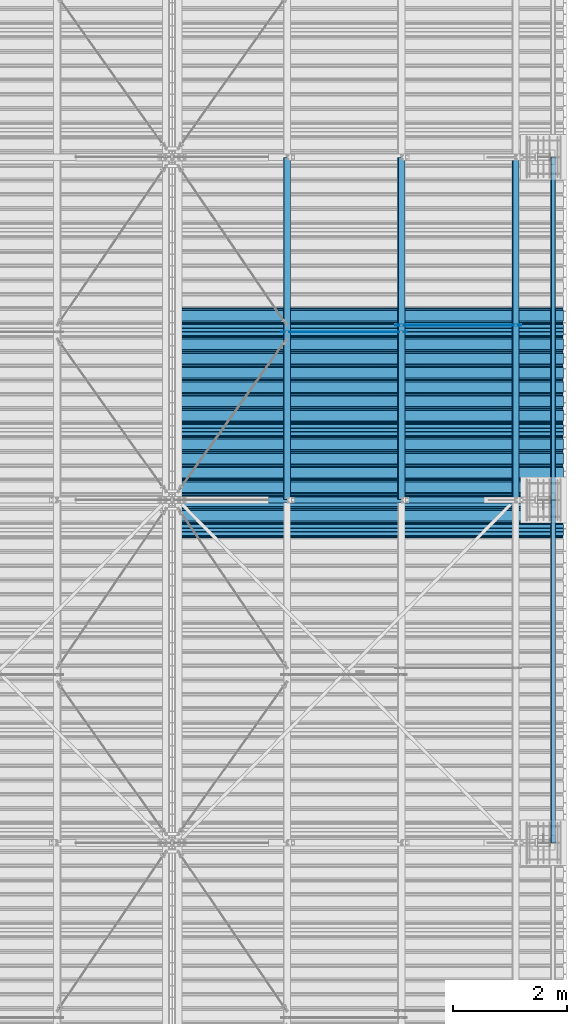
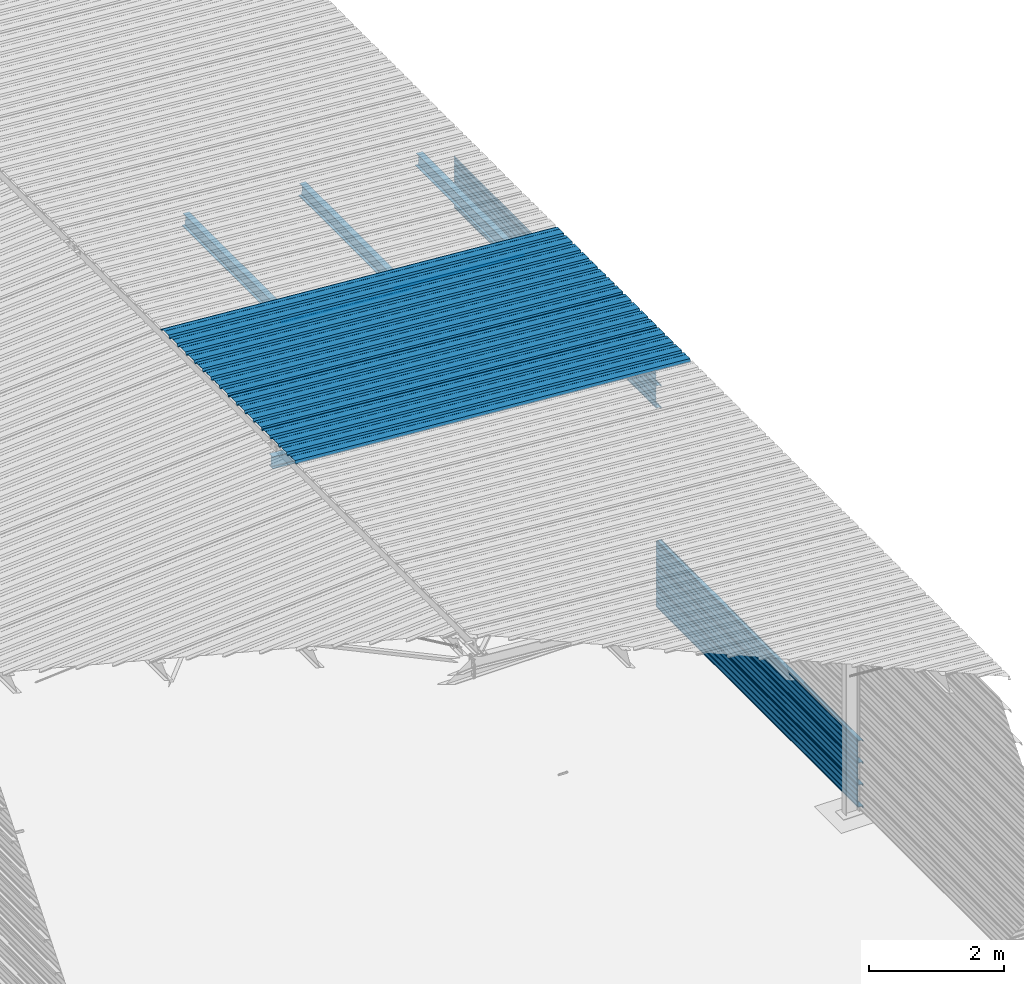
# One storey, part 14 of 70: 16 beams, 16 elements without a shape of their own.
"""IFC2X3 building model written with IfcOpenShell, lengths in millimetres."""

from ifc_helpers import new_model, si_unit, frame, origin_with_axes, origin_2d_with_axis, place, context, subcontext, project, spatial, polyline, circle, i_section, outline, extrude, clip, halfspace, material, type_object, element, aggregate, save


model = new_model("IFC2X3")

# Units and contexts
model_context = context("Model", 3, precision=1e-05, world=origin_with_axes())
body_context = subcontext(model_context, "Body", "Model", "MODEL_VIEW")
ifc_project = project(units=[si_unit("LENGTHUNIT", "METRE", prefix="MILLI"), si_unit("AREAUNIT", "SQUARE_METRE"), si_unit("VOLUMEUNIT", "CUBIC_METRE"), si_unit("MASSUNIT", "GRAM", prefix="KILO"), si_unit("TIMEUNIT", "SECOND"), si_unit("PLANEANGLEUNIT", "RADIAN"), si_unit("SOLIDANGLEUNIT", "STERADIAN"), si_unit("THERMODYNAMICTEMPERATUREUNIT", "DEGREE_CELSIUS"), si_unit("LUMINOUSINTENSITYUNIT", "LUMEN")], contexts=[model_context])

# Site, building, storey
site_placement = place(None, origin_with_axes())
site = spatial("IfcSite", under=ifc_project, at=site_placement, CompositionType="ELEMENT")
building_placement = place(site_placement, origin_with_axes())
building = spatial("IfcBuilding", under=site, at=building_placement, Name="Undefined", CompositionType="ELEMENT")
storey_placement = place(building_placement, origin_with_axes())
storey = spatial("IfcBuildingStorey", under=building, at=storey_placement, Name="Undefined", CompositionType="ELEMENT", Elevation=0.0)

# Assembly, beam
assembly_1_placement = place(storey_placement, origin_with_axes())
assembly_1 = element("IfcElementAssembly", 1, at=assembly_1_placement, inside=storey, Name="Steel Assembly", AssemblyPlace="NOTDEFINED", PredefinedType="RIGID_FRAME")
ifc_material = material(Name="STEEL/S235JR")
beam_type_1 = type_object("IfcBeamType", Name="4.40", PredefinedType="NOTDEFINED")
beam_1_placement = place(assembly_1_placement, frame((6563.60751131961, 11850.0000000002, 5336.31760454384), z_axis=(-0.0766964990376782, 0.0, -0.997054485489817), x_axis=(0.997054485489817, 0.0, -0.0766964990376783)))
beam_1 = element("IfcBeam", 2, at=beam_1_placement, type_object=beam_type_1, material=ifc_material, ObjectType="4.40", context=body_context, shape_type="SweptSolid", body=[
    extrude(outline(polyline([(509.415161132813, 19.5000000011705), (490.584838867188, 19.5000000011705), (468.084838867188, -20.4999999988113), (406.585784912109, -20.4999999988113), (404.585784912109, -18.4999999988122), (345.414215087891, -18.4999999988122), (343.414215087891, -20.4999999988113), (281.915161132813, -20.4999999988113), (259.415161132813, 19.5000000011705), (240.584854125977, 19.5000000011705), (218.084854125977, -20.4999999988113), (156.585784912109, -20.4999999988113), (154.585784912109, -18.4999999988122), (95.4142150878906, -18.4999999988122), (93.4142150878906, -20.4999999988113), (31.9151515960693, -20.4999999988113), (9.41515254974365, 19.5000000011705), (-9.41515254974365, 19.5000000011705), (-31.9151515960693, -20.4999999988113), (-93.4142150878906, -20.4999999988113), (-95.4142150878906, -18.4999999988122), (-154.585784912109, -18.4999999988122), (-156.585784912109, -20.4999999988113), (-218.084854125977, -20.4999999988113), (-240.584854125977, 19.5000000011705), (-259.415161132813, 19.5000000011705), (-281.915161132813, -20.4999999988113), (-343.414215087891, -20.4999999988113), (-345.414215087891, -18.4999999988122), (-404.585784912109, -18.4999999988122), (-406.585784912109, -20.4999999988113), (-468.084838867188, -20.4999999988113), (-490.584838867188, 19.5000000011705), (-509.415161132813, 19.5000000011705), (-516.482360839844, 6.9361057293263), (-517.353942871094, 7.42636680720625), (-510.0, 20.5000000011705), (-490.0, 20.5000000011705), (-467.5, -19.4999999988122), (-407.0, -19.4999999988122), (-405.0, -17.4999999988131), (-345.0, -17.4999999988131), (-343.0, -19.4999999988122), (-282.5, -19.4999999988122), (-260.0, 20.5000000011705), (-240.0, 20.5000000011705), (-217.5, -19.4999999988122), (-157.0, -19.4999999988122), (-155.0, -17.4999999988131), (-95.0, -17.4999999988131), (-93.0, -19.4999999988122), (-32.5, -19.4999999988122), (-10.0, 20.5000000011705), (10.0, 20.5000000011705), (32.5, -19.4999999988122), (93.0, -19.4999999988122), (95.0, -17.4999999988131), (155.0, -17.4999999988131), (157.0, -19.4999999988122), (217.5, -19.4999999988122), (240.0, 20.5000000011705), (260.0, 20.5000000011705), (282.5, -19.4999999988122), (343.0, -19.4999999988122), (345.0, -17.4999999988131), (405.0, -17.4999999988131), (407.0, -19.4999999988122), (467.5, -19.4999999988122), (490.0, 20.5000000011705), (510.0, 20.5000000011705), (517.353942871094, 7.42636680720625), (516.482360839844, 6.9361057293263), (509.415161132813, 19.5000000011705)])), frame((6799.99999999733, 2.8421709430404e-14, 0.0), z_axis=(-1.0, 0.0, 0.0), x_axis=(0.0, -1.0, 0.0)), (0.0, 0.0, 1.0), 6800.0),
])
aggregate(assembly_1, [beam_1])

assembly_2_placement = place(storey_placement, origin_with_axes())
assembly_2 = element("IfcElementAssembly", 3, at=assembly_2_placement, inside=storey, Name="Steel Assembly", AssemblyPlace="NOTDEFINED", PredefinedType="RIGID_FRAME")
beam_2_placement = place(assembly_2_placement, frame((6563.60751131961, 12850.0000000002, 5336.31760454387), z_axis=(-0.0766964990376782, 0.0, -0.997054485489817), x_axis=(0.997054485489817, 0.0, -0.0766964990376783)))
beam_2 = element("IfcBeam", 4, at=beam_2_placement, type_object=beam_type_1, material=ifc_material, ObjectType="4.40", context=body_context, shape_type="SweptSolid", body=[
    extrude(outline(polyline([(509.415161132813, 19.5000000011705), (490.584838867188, 19.5000000011705), (468.084838867188, -20.4999999988113), (406.585784912109, -20.4999999988113), (404.585784912109, -18.4999999988122), (345.414215087891, -18.4999999988122), (343.414215087891, -20.4999999988113), (281.915161132813, -20.4999999988113), (259.415161132813, 19.5000000011705), (240.584854125977, 19.5000000011705), (218.084854125977, -20.4999999988113), (156.585784912109, -20.4999999988113), (154.585784912109, -18.4999999988122), (95.4142150878906, -18.4999999988122), (93.4142150878906, -20.4999999988113), (31.9151515960693, -20.4999999988113), (9.41515254974365, 19.5000000011705), (-9.41515254974365, 19.5000000011705), (-31.9151515960693, -20.4999999988113), (-93.4142150878906, -20.4999999988113), (-95.4142150878906, -18.4999999988122), (-154.585784912109, -18.4999999988122), (-156.585784912109, -20.4999999988113), (-218.084854125977, -20.4999999988113), (-240.584854125977, 19.5000000011705), (-259.415161132813, 19.5000000011705), (-281.915161132813, -20.4999999988113), (-343.414215087891, -20.4999999988113), (-345.414215087891, -18.4999999988122), (-404.585784912109, -18.4999999988122), (-406.585784912109, -20.4999999988113), (-468.084838867188, -20.4999999988113), (-490.584838867188, 19.5000000011705), (-509.415161132813, 19.5000000011705), (-516.482360839844, 6.9361057293263), (-517.353942871094, 7.42636680720625), (-510.0, 20.5000000011705), (-490.0, 20.5000000011705), (-467.5, -19.4999999988122), (-407.0, -19.4999999988122), (-405.0, -17.4999999988131), (-345.0, -17.4999999988131), (-343.0, -19.4999999988122), (-282.5, -19.4999999988122), (-260.0, 20.5000000011705), (-240.0, 20.5000000011705), (-217.5, -19.4999999988122), (-157.0, -19.4999999988122), (-155.0, -17.4999999988131), (-95.0, -17.4999999988131), (-93.0, -19.4999999988122), (-32.5, -19.4999999988122), (-10.0, 20.5000000011705), (10.0, 20.5000000011705), (32.5, -19.4999999988122), (93.0, -19.4999999988122), (95.0, -17.4999999988131), (155.0, -17.4999999988131), (157.0, -19.4999999988122), (217.5, -19.4999999988122), (240.0, 20.5000000011705), (260.0, 20.5000000011705), (282.5, -19.4999999988122), (343.0, -19.4999999988122), (345.0, -17.4999999988131), (405.0, -17.4999999988131), (407.0, -19.4999999988122), (467.5, -19.4999999988122), (490.0, 20.5000000011705), (510.0, 20.5000000011705), (517.353942871094, 7.42636680720625), (516.482360839844, 6.9361057293263), (509.415161132813, 19.5000000011705)])), frame((6799.99999999733, 2.8421709430404e-14, 0.0), z_axis=(-1.0, 0.0, 0.0), x_axis=(0.0, -1.0, 0.0)), (0.0, 0.0, 1.0), 6800.0),
])
aggregate(assembly_2, [beam_2])

assembly_3_placement = place(storey_placement, origin_with_axes())
assembly_3 = element("IfcElementAssembly", 5, at=assembly_3_placement, inside=storey, Name="Steel Assembly", AssemblyPlace="NOTDEFINED", PredefinedType="RIGID_FRAME")
beam_3_placement = place(assembly_3_placement, frame((6563.60751131961, 13850.0000000002, 5336.31760454389), z_axis=(-0.0766964990376782, 0.0, -0.997054485489817), x_axis=(0.997054485489817, 0.0, -0.0766964990376783)))
beam_3 = element("IfcBeam", 6, at=beam_3_placement, type_object=beam_type_1, material=ifc_material, ObjectType="4.40", context=body_context, shape_type="SweptSolid", body=[
    extrude(outline(polyline([(509.415161132813, 19.5000000011705), (490.584838867188, 19.5000000011705), (468.084838867188, -20.4999999988113), (406.585784912109, -20.4999999988113), (404.585784912109, -18.4999999988122), (345.414215087891, -18.4999999988122), (343.414215087891, -20.4999999988113), (281.915161132813, -20.4999999988113), (259.415161132813, 19.5000000011705), (240.584854125977, 19.5000000011705), (218.084854125977, -20.4999999988113), (156.585784912109, -20.4999999988113), (154.585784912109, -18.4999999988122), (95.4142150878906, -18.4999999988122), (93.4142150878906, -20.4999999988113), (31.9151515960693, -20.4999999988113), (9.41515254974365, 19.5000000011705), (-9.41515254974365, 19.5000000011705), (-31.9151515960693, -20.4999999988113), (-93.4142150878906, -20.4999999988113), (-95.4142150878906, -18.4999999988122), (-154.585784912109, -18.4999999988122), (-156.585784912109, -20.4999999988113), (-218.084854125977, -20.4999999988113), (-240.584854125977, 19.5000000011705), (-259.415161132813, 19.5000000011705), (-281.915161132813, -20.4999999988113), (-343.414215087891, -20.4999999988113), (-345.414215087891, -18.4999999988122), (-404.585784912109, -18.4999999988122), (-406.585784912109, -20.4999999988113), (-468.084838867188, -20.4999999988113), (-490.584838867188, 19.5000000011705), (-509.415161132813, 19.5000000011705), (-516.482360839844, 6.9361057293263), (-517.353942871094, 7.42636680720625), (-510.0, 20.5000000011705), (-490.0, 20.5000000011705), (-467.5, -19.4999999988122), (-407.0, -19.4999999988122), (-405.0, -17.4999999988131), (-345.0, -17.4999999988131), (-343.0, -19.4999999988122), (-282.5, -19.4999999988122), (-260.0, 20.5000000011705), (-240.0, 20.5000000011705), (-217.5, -19.4999999988122), (-157.0, -19.4999999988122), (-155.0, -17.4999999988131), (-95.0, -17.4999999988131), (-93.0, -19.4999999988122), (-32.5, -19.4999999988122), (-10.0, 20.5000000011705), (10.0, 20.5000000011705), (32.5, -19.4999999988122), (93.0, -19.4999999988122), (95.0, -17.4999999988131), (155.0, -17.4999999988131), (157.0, -19.4999999988122), (217.5, -19.4999999988122), (240.0, 20.5000000011705), (260.0, 20.5000000011705), (282.5, -19.4999999988122), (343.0, -19.4999999988122), (345.0, -17.4999999988131), (405.0, -17.4999999988131), (407.0, -19.4999999988122), (467.5, -19.4999999988122), (490.0, 20.5000000011705), (510.0, 20.5000000011705), (517.353942871094, 7.42636680720625), (516.482360839844, 6.9361057293263), (509.415161132813, 19.5000000011705)])), frame((6799.99999999733, 2.8421709430404e-14, 0.0), z_axis=(-1.0, 0.0, 0.0), x_axis=(0.0, -1.0, 0.0)), (0.0, 0.0, 1.0), 6800.0),
])
aggregate(assembly_3, [beam_3])

assembly_4_placement = place(storey_placement, origin_with_axes())
assembly_4 = element("IfcElementAssembly", 7, at=assembly_4_placement, inside=storey, Name="Steel Assembly", AssemblyPlace="NOTDEFINED", PredefinedType="RIGID_FRAME")
beam_4_placement = place(assembly_4_placement, frame((6563.60751131961, 14850.0000000002, 5336.31760454392), z_axis=(-0.0766964990376782, 0.0, -0.997054485489817), x_axis=(0.997054485489817, 0.0, -0.0766964990376783)))
beam_4 = element("IfcBeam", 8, at=beam_4_placement, type_object=beam_type_1, material=ifc_material, ObjectType="4.40", context=body_context, shape_type="SweptSolid", body=[
    extrude(outline(polyline([(509.415161132813, 19.5000000011705), (490.584838867188, 19.5000000011705), (468.084838867188, -20.4999999988113), (406.585784912109, -20.4999999988113), (404.585784912109, -18.4999999988122), (345.414215087891, -18.4999999988122), (343.414215087891, -20.4999999988113), (281.915161132813, -20.4999999988113), (259.415161132813, 19.5000000011705), (240.584854125977, 19.5000000011705), (218.084854125977, -20.4999999988113), (156.585784912109, -20.4999999988113), (154.585784912109, -18.4999999988122), (95.4142150878906, -18.4999999988122), (93.4142150878906, -20.4999999988113), (31.9151515960693, -20.4999999988113), (9.41515254974365, 19.5000000011705), (-9.41515254974365, 19.5000000011705), (-31.9151515960693, -20.4999999988113), (-93.4142150878906, -20.4999999988113), (-95.4142150878906, -18.4999999988122), (-154.585784912109, -18.4999999988122), (-156.585784912109, -20.4999999988113), (-218.084854125977, -20.4999999988113), (-240.584854125977, 19.5000000011705), (-259.415161132813, 19.5000000011705), (-281.915161132813, -20.4999999988113), (-343.414215087891, -20.4999999988113), (-345.414215087891, -18.4999999988122), (-404.585784912109, -18.4999999988122), (-406.585784912109, -20.4999999988113), (-468.084838867188, -20.4999999988113), (-490.584838867188, 19.5000000011705), (-509.415161132813, 19.5000000011705), (-516.482360839844, 6.9361057293263), (-517.353942871094, 7.42636680720625), (-510.0, 20.5000000011705), (-490.0, 20.5000000011705), (-467.5, -19.4999999988122), (-407.0, -19.4999999988122), (-405.0, -17.4999999988131), (-345.0, -17.4999999988131), (-343.0, -19.4999999988122), (-282.5, -19.4999999988122), (-260.0, 20.5000000011705), (-240.0, 20.5000000011705), (-217.5, -19.4999999988122), (-157.0, -19.4999999988122), (-155.0, -17.4999999988131), (-95.0, -17.4999999988131), (-93.0, -19.4999999988122), (-32.5, -19.4999999988122), (-10.0, 20.5000000011705), (10.0, 20.5000000011705), (32.5, -19.4999999988122), (93.0, -19.4999999988122), (95.0, -17.4999999988131), (155.0, -17.4999999988131), (157.0, -19.4999999988122), (217.5, -19.4999999988122), (240.0, 20.5000000011705), (260.0, 20.5000000011705), (282.5, -19.4999999988122), (343.0, -19.4999999988122), (345.0, -17.4999999988131), (405.0, -17.4999999988131), (407.0, -19.4999999988122), (467.5, -19.4999999988122), (490.0, 20.5000000011705), (510.0, 20.5000000011705), (517.353942871094, 7.42636680720625), (516.482360839844, 6.9361057293263), (509.415161132813, 19.5000000011705)])), frame((6799.99999999733, 2.8421709430404e-14, 0.0), z_axis=(-1.0, 0.0, 0.0), x_axis=(0.0, -1.0, 0.0)), (0.0, 0.0, 1.0), 6800.0),
])
aggregate(assembly_4, [beam_4])

assembly_5_placement = place(storey_placement, origin_with_axes())
assembly_5 = element("IfcElementAssembly", 9, at=assembly_5_placement, inside=storey, Name="Steel Assembly", AssemblyPlace="NOTDEFINED", PredefinedType="RIGID_FRAME")
beam_type_2 = type_object("IfcBeamType", Name="400", PredefinedType="NOTDEFINED")
beam_5_placement = place(assembly_5_placement, frame((13165.4999999983, 18000.0, 4618.17396601053), z_axis=(1.0, 0.0, 0.0), x_axis=(0.0, -1.0, 0.0)))
beam_5 = element("IfcBeam", 10, at=beam_5_placement, type_object=beam_type_2, material=ifc_material, ObjectType="400", context=body_context, shape_type="Clipping", body=[
    clip(extrude(outline(polyline([(218.25, -24.994083404541), (214.25, -31.8999996185303), (214.25, -45.5), (199.75, -45.5), (194.25, -42.5), (188.75, -45.5), (124.25, -45.5), (114.25, -41.5), (104.25, -45.5), (24.25, -45.5), (14.25, -41.5), (4.25, -45.5), (-75.75, -45.5), (-85.75, -41.5), (-95.75, -45.5), (-160.25, -45.5), (-165.75, -42.5), (-171.25, -45.5), (-185.75, -45.5), (-185.75, -30.711540222168), (-181.75, -23.8111782073975), (-181.75, 23.311637878418), (-185.75, 30.2119998931885), (-185.75, 44.5), (-217.25, 44.5), (-217.25, 34.7999992370605), (-218.25, 34.7999992370605), (-218.25, 45.5), (-184.75, 45.5), (-184.75, 30.480884552002), (-180.75, 23.5805225372314), (-180.75, -24.0800628662109), (-184.75, -30.9804248809814), (-184.75, -44.5), (-171.504989624023, -44.5), (-165.75, -41.360912322998), (-159.995010375977, -44.5), (-95.9425811767578, -44.5), (-85.75, -40.422966003418), (-75.5574188232422, -44.5), (4.05741739273071, -44.5), (14.25, -40.422966003418), (24.4425830841064, -44.5), (104.057418823242, -44.5), (114.25, -40.422966003418), (124.442581176758, -44.5), (188.495010375977, -44.5), (194.25, -41.360912322998), (200.004989624023, -44.5), (213.25, -44.5), (213.25, -31.6313018798828), (217.25, -24.7253856658936), (217.25, 21.7253856658936), (213.25, 28.6313018798828), (213.25, 42.0), (187.25, 42.0), (187.25, 32.5499992370605), (186.25, 32.5499992370605), (186.25, 43.0), (214.25, 43.0), (214.25, 28.8999996185303), (218.25, 21.994083404541), (218.25, -24.994083404541)])), frame((6000.0, 0.0, 0.0), z_axis=(-1.0, 0.0, 0.0), x_axis=(0.0, -1.0, 0.0)), (0.0, 0.0, 1.0), 6000.0), halfspace(frame((6000.0, 36.6804312648892, -44.9999999999927), z_axis=(0.0, -1.0, 0.0), x_axis=(-1.0, 0.0, 0.0)), False)),
])
aggregate(assembly_5, [beam_5])

assembly_6_placement = place(storey_placement, origin_with_axes())
assembly_6 = element("IfcElementAssembly", 11, at=assembly_6_placement, inside=storey, Name="Steel Assembly", AssemblyPlace="NOTDEFINED", PredefinedType="RIGID_FRAME")
beam_6_placement = place(assembly_6_placement, frame((13165.4999999985, 18000.0, 4218.17396601053), z_axis=(1.0, 0.0, 0.0), x_axis=(0.0, -1.0, 0.0)))
beam_6 = element("IfcBeam", 12, at=beam_6_placement, type_object=beam_type_2, material=ifc_material, ObjectType="400", context=body_context, shape_type="SweptSolid", body=[
    extrude(outline(polyline([(218.25, -24.994083404541), (214.25, -31.8999996185303), (214.25, -45.5), (199.75, -45.5), (194.25, -42.5), (188.75, -45.5), (124.25, -45.5), (114.25, -41.5), (104.25, -45.5), (24.25, -45.5), (14.25, -41.5), (4.25, -45.5), (-75.75, -45.5), (-85.75, -41.5), (-95.75, -45.5), (-160.25, -45.5), (-165.75, -42.5), (-171.25, -45.5), (-185.75, -45.5), (-185.75, -30.711540222168), (-181.75, -23.8111782073975), (-181.75, 23.311637878418), (-185.75, 30.2119998931885), (-185.75, 44.5), (-217.25, 44.5), (-217.25, 34.7999992370605), (-218.25, 34.7999992370605), (-218.25, 45.5), (-184.75, 45.5), (-184.75, 30.480884552002), (-180.75, 23.5805225372314), (-180.75, -24.0800628662109), (-184.75, -30.9804248809814), (-184.75, -44.5), (-171.504989624023, -44.5), (-165.75, -41.360912322998), (-159.995010375977, -44.5), (-95.9425811767578, -44.5), (-85.75, -40.422966003418), (-75.5574188232422, -44.5), (4.05741739273071, -44.5), (14.25, -40.422966003418), (24.4425830841064, -44.5), (104.057418823242, -44.5), (114.25, -40.422966003418), (124.442581176758, -44.5), (188.495010375977, -44.5), (194.25, -41.360912322998), (200.004989624023, -44.5), (213.25, -44.5), (213.25, -31.6313018798828), (217.25, -24.7253856658936), (217.25, 21.7253856658936), (213.25, 28.6313018798828), (213.25, 42.0), (187.25, 42.0), (187.25, 32.5499992370605), (186.25, 32.5499992370605), (186.25, 43.0), (214.25, 43.0), (214.25, 28.8999996185303), (218.25, 21.994083404541), (218.25, -24.994083404541)])), frame((6000.0, 0.0, 0.0), z_axis=(-1.0, 0.0, 0.0), x_axis=(0.0, -1.0, 0.0)), (0.0, 0.0, 1.0), 6000.0),
])
aggregate(assembly_6, [beam_6])

assembly_7_placement = place(storey_placement, origin_with_axes())
assembly_7 = element("IfcElementAssembly", 13, at=assembly_7_placement, inside=storey, Name="Steel Assembly", AssemblyPlace="NOTDEFINED", PredefinedType="RIGID_FRAME")
beam_7_placement = place(assembly_7_placement, frame((13165.4999999986, 18000.0, 3818.17396601053), z_axis=(1.0, 0.0, 0.0), x_axis=(0.0, -1.0, 0.0)))
beam_7 = element("IfcBeam", 14, at=beam_7_placement, type_object=beam_type_2, material=ifc_material, ObjectType="400", context=body_context, shape_type="SweptSolid", body=[
    extrude(outline(polyline([(218.25, -24.994083404541), (214.25, -31.8999996185303), (214.25, -45.5), (199.75, -45.5), (194.25, -42.5), (188.75, -45.5), (124.25, -45.5), (114.25, -41.5), (104.25, -45.5), (24.25, -45.5), (14.25, -41.5), (4.25, -45.5), (-75.75, -45.5), (-85.75, -41.5), (-95.75, -45.5), (-160.25, -45.5), (-165.75, -42.5), (-171.25, -45.5), (-185.75, -45.5), (-185.75, -30.711540222168), (-181.75, -23.8111782073975), (-181.75, 23.311637878418), (-185.75, 30.2119998931885), (-185.75, 44.5), (-217.25, 44.5), (-217.25, 34.7999992370605), (-218.25, 34.7999992370605), (-218.25, 45.5), (-184.75, 45.5), (-184.75, 30.480884552002), (-180.75, 23.5805225372314), (-180.75, -24.0800628662109), (-184.75, -30.9804248809814), (-184.75, -44.5), (-171.504989624023, -44.5), (-165.75, -41.360912322998), (-159.995010375977, -44.5), (-95.9425811767578, -44.5), (-85.75, -40.422966003418), (-75.5574188232422, -44.5), (4.05741739273071, -44.5), (14.25, -40.422966003418), (24.4425830841064, -44.5), (104.057418823242, -44.5), (114.25, -40.422966003418), (124.442581176758, -44.5), (188.495010375977, -44.5), (194.25, -41.360912322998), (200.004989624023, -44.5), (213.25, -44.5), (213.25, -31.6313018798828), (217.25, -24.7253856658936), (217.25, 21.7253856658936), (213.25, 28.6313018798828), (213.25, 42.0), (187.25, 42.0), (187.25, 32.5499992370605), (186.25, 32.5499992370605), (186.25, 43.0), (214.25, 43.0), (214.25, 28.8999996185303), (218.25, 21.994083404541), (218.25, -24.994083404541)])), frame((6000.0, 0.0, 0.0), z_axis=(-1.0, 0.0, 0.0), x_axis=(0.0, -1.0, 0.0)), (0.0, 0.0, 1.0), 6000.0),
])
aggregate(assembly_7, [beam_7])

assembly_8_placement = place(storey_placement, origin_with_axes())
assembly_8 = element("IfcElementAssembly", 15, at=assembly_8_placement, inside=storey, Name="Steel Assembly", AssemblyPlace="NOTDEFINED", PredefinedType="RIGID_FRAME")
beam_8_placement = place(assembly_8_placement, frame((13165.4999999997, 12000.0, 1018.17396601053), z_axis=(1.0, 0.0, 0.0), x_axis=(0.0, -1.0, 0.0)))
beam_8 = element("IfcBeam", 16, at=beam_8_placement, type_object=beam_type_2, material=ifc_material, ObjectType="400", context=body_context, shape_type="SweptSolid", body=[
    extrude(outline(polyline([(218.25, -24.994083404541), (214.25, -31.8999996185303), (214.25, -45.5), (199.75, -45.5), (194.25, -42.5), (188.75, -45.5), (124.25, -45.5), (114.25, -41.5), (104.25, -45.5), (24.25, -45.5), (14.25, -41.5), (4.25, -45.5), (-75.75, -45.5), (-85.75, -41.5), (-95.75, -45.5), (-160.25, -45.5), (-165.75, -42.5), (-171.25, -45.5), (-185.75, -45.5), (-185.75, -30.711540222168), (-181.75, -23.8111782073975), (-181.75, 23.311637878418), (-185.75, 30.2119998931885), (-185.75, 44.5), (-217.25, 44.5), (-217.25, 34.7999992370605), (-218.25, 34.7999992370605), (-218.25, 45.5), (-184.75, 45.5), (-184.75, 30.480884552002), (-180.75, 23.5805225372314), (-180.75, -24.0800628662109), (-184.75, -30.9804248809814), (-184.75, -44.5), (-171.504989624023, -44.5), (-165.75, -41.360912322998), (-159.995010375977, -44.5), (-95.9425811767578, -44.5), (-85.75, -40.422966003418), (-75.5574188232422, -44.5), (4.05741739273071, -44.5), (14.25, -40.422966003418), (24.4425830841064, -44.5), (104.057418823242, -44.5), (114.25, -40.422966003418), (124.442581176758, -44.5), (188.495010375977, -44.5), (194.25, -41.360912322998), (200.004989624023, -44.5), (213.25, -44.5), (213.25, -31.6313018798828), (217.25, -24.7253856658936), (217.25, 21.7253856658936), (213.25, 28.6313018798828), (213.25, 42.0), (187.25, 42.0), (187.25, 32.5499992370605), (186.25, 32.5499992370605), (186.25, 43.0), (214.25, 43.0), (214.25, 28.8999996185303), (218.25, 21.994083404541), (218.25, -24.994083404541)])), frame((6000.0, 0.0, 0.0), z_axis=(-1.0, 0.0, 0.0), x_axis=(0.0, -1.0, 0.0)), (0.0, 0.0, 1.0), 6000.0),
])
aggregate(assembly_8, [beam_8])

assembly_9_placement = place(storey_placement, origin_with_axes())
assembly_9 = element("IfcElementAssembly", 17, at=assembly_9_placement, inside=storey, Name="Steel Assembly", AssemblyPlace="NOTDEFINED", PredefinedType="RIGID_FRAME")
beam_9_placement = place(assembly_9_placement, frame((13165.4999999998, 12000.0, 618.173966010529), z_axis=(1.0, 0.0, 0.0), x_axis=(0.0, -1.0, 0.0)))
beam_9 = element("IfcBeam", 18, at=beam_9_placement, type_object=beam_type_2, material=ifc_material, ObjectType="400", context=body_context, shape_type="SweptSolid", body=[
    extrude(outline(polyline([(218.25, -24.994083404541), (214.25, -31.8999996185303), (214.25, -45.5), (199.75, -45.5), (194.25, -42.5), (188.75, -45.5), (124.25, -45.5), (114.25, -41.5), (104.25, -45.5), (24.25, -45.5), (14.25, -41.5), (4.25, -45.5), (-75.75, -45.5), (-85.75, -41.5), (-95.75, -45.5), (-160.25, -45.5), (-165.75, -42.5), (-171.25, -45.5), (-185.75, -45.5), (-185.75, -30.711540222168), (-181.75, -23.8111782073975), (-181.75, 23.311637878418), (-185.75, 30.2119998931885), (-185.75, 44.5), (-217.25, 44.5), (-217.25, 34.7999992370605), (-218.25, 34.7999992370605), (-218.25, 45.5), (-184.75, 45.5), (-184.75, 30.480884552002), (-180.75, 23.5805225372314), (-180.75, -24.0800628662109), (-184.75, -30.9804248809814), (-184.75, -44.5), (-171.504989624023, -44.5), (-165.75, -41.360912322998), (-159.995010375977, -44.5), (-95.9425811767578, -44.5), (-85.75, -40.422966003418), (-75.5574188232422, -44.5), (4.05741739273071, -44.5), (14.25, -40.422966003418), (24.4425830841064, -44.5), (104.057418823242, -44.5), (114.25, -40.422966003418), (124.442581176758, -44.5), (188.495010375977, -44.5), (194.25, -41.360912322998), (200.004989624023, -44.5), (213.25, -44.5), (213.25, -31.6313018798828), (217.25, -24.7253856658936), (217.25, 21.7253856658936), (213.25, 28.6313018798828), (213.25, 42.0), (187.25, 42.0), (187.25, 32.5499992370605), (186.25, 32.5499992370605), (186.25, 43.0), (214.25, 43.0), (214.25, 28.8999996185303), (218.25, 21.994083404541), (218.25, -24.994083404541)])), frame((6000.0, 0.0, 0.0), z_axis=(-1.0, 0.0, 0.0), x_axis=(0.0, -1.0, 0.0)), (0.0, 0.0, 1.0), 6000.0),
])
aggregate(assembly_9, [beam_9])

assembly_10_placement = place(storey_placement, origin_with_axes())
assembly_10 = element("IfcElementAssembly", 19, at=assembly_10_placement, inside=storey, Name="Steel Assembly", AssemblyPlace="NOTDEFINED", PredefinedType="RIGID_FRAME")
beam_10_placement = place(assembly_10_placement, frame((13165.5, 12000.0, 218.173966010529), z_axis=(1.0, 0.0, 0.0), x_axis=(0.0, -1.0, 0.0)))
beam_10 = element("IfcBeam", 20, at=beam_10_placement, type_object=beam_type_2, material=ifc_material, ObjectType="400", context=body_context, shape_type="SweptSolid", body=[
    extrude(outline(polyline([(218.25, -24.994083404541), (214.25, -31.8999996185303), (214.25, -45.5), (199.75, -45.5), (194.25, -42.5), (188.75, -45.5), (124.25, -45.5), (114.25, -41.5), (104.25, -45.5), (24.25, -45.5), (14.25, -41.5), (4.25, -45.5), (-75.75, -45.5), (-85.75, -41.5), (-95.75, -45.5), (-160.25, -45.5), (-165.75, -42.5), (-171.25, -45.5), (-185.75, -45.5), (-185.75, -30.711540222168), (-181.75, -23.8111782073975), (-181.75, 23.311637878418), (-185.75, 30.2119998931885), (-185.75, 44.5), (-217.25, 44.5), (-217.25, 34.7999992370605), (-218.25, 34.7999992370605), (-218.25, 45.5), (-184.75, 45.5), (-184.75, 30.480884552002), (-180.75, 23.5805225372314), (-180.75, -24.0800628662109), (-184.75, -30.9804248809814), (-184.75, -44.5), (-171.504989624023, -44.5), (-165.75, -41.360912322998), (-159.995010375977, -44.5), (-95.9425811767578, -44.5), (-85.75, -40.422966003418), (-75.5574188232422, -44.5), (4.05741739273071, -44.5), (14.25, -40.422966003418), (24.4425830841064, -44.5), (104.057418823242, -44.5), (114.25, -40.422966003418), (124.442581176758, -44.5), (188.495010375977, -44.5), (194.25, -41.360912322998), (200.004989624023, -44.5), (213.25, -44.5), (213.25, -31.6313018798828), (217.25, -24.7253856658936), (217.25, 21.7253856658936), (213.25, 28.6313018798828), (213.25, 42.0), (187.25, 42.0), (187.25, 32.5499992370605), (186.25, 32.5499992370605), (186.25, 43.0), (214.25, 43.0), (214.25, 28.8999996185303), (218.25, 21.994083404541), (218.25, -24.994083404541)])), frame((6000.0, 0.0, 0.0), z_axis=(-1.0, 0.0, 0.0), x_axis=(0.0, -1.0, 0.0)), (0.0, 0.0, 1.0), 6000.0),
])
aggregate(assembly_10, [beam_10])

assembly_11_placement = place(storey_placement, origin_with_axes())
assembly_11 = element("IfcElementAssembly", 21, at=assembly_11_placement, inside=storey, Name="Steel Assembly", AssemblyPlace="NOTDEFINED", PredefinedType="RIGID_FRAME")
beam_type_3 = type_object("IfcBeamType", Name="D14", PredefinedType="NOTDEFINED")
beam_11_placement = place(assembly_11_placement, frame((10408.7311663468, 15060.0000000001, 4909.65333500212), z_axis=(-0.0766964990376782, 0.0, -0.997054485489817), x_axis=(0.997054485489817, 0.0, -0.0766964990376783)))
beam_11 = element("IfcBeam", 22, at=beam_11_placement, type_object=beam_type_3, material=ifc_material, Name="THREAD60MM", ObjectType="D14", context=body_context, shape_type="SweptSolid", body=[
    extrude(circle(Radius=7.0, at=origin_2d_with_axis()), frame((2205.90843239298, 9.09494701772928e-13, -9.40107830921147e-13), z_axis=(-1.0, 0.0, 0.0), x_axis=(0.0, -1.0, 0.0)), (0.0, 0.0, 1.0), 2205.91),
])
aggregate(assembly_11, [beam_11])

assembly_12_placement = place(storey_placement, origin_with_axes())
assembly_12 = element("IfcElementAssembly", 23, at=assembly_12_placement, inside=storey, Name="Steel Assembly", AssemblyPlace="NOTDEFINED", PredefinedType="RIGID_FRAME")
beam_12_placement = place(assembly_12_placement, frame((8408.73116634676, 14940.0000000001, 5063.49948915789), z_axis=(-0.0766964990376782, 0.0, -0.997054485489817), x_axis=(0.997054485489817, 0.0, -0.0766964990376783)))
beam_12 = element("IfcBeam", 24, at=beam_12_placement, type_object=beam_type_3, material=ifc_material, Name="THREAD60MM", ObjectType="D14", context=body_context, shape_type="SweptSolid", body=[
    extrude(circle(Radius=7.0, at=origin_2d_with_axis()), frame((2205.90843239298, 9.09494701772928e-13, -9.40107830921147e-13), z_axis=(-1.0, 0.0, 0.0), x_axis=(0.0, -1.0, 0.0)), (0.0, 0.0, 1.0), 2205.91),
])
aggregate(assembly_12, [beam_12])

assembly_13_placement = place(storey_placement, origin_with_axes())
assembly_13 = element("IfcElementAssembly", 25, at=assembly_13_placement, inside=storey, Name="Steel Assembly", AssemblyPlace="NOTDEFINED", PredefinedType="RIGID_FRAME")
beam_type_4 = type_object("IfcBeamType", Name="IPE220", PredefinedType="NOTDEFINED")
beam_13_placement = place(assembly_13_placement, frame((12508.436614895, 12000.0, 4748.1375309431), z_axis=(0.0766964990376782, 0.0, 0.997054485489817), x_axis=(0.0, 1.0, 0.0)))
beam_13 = element("IfcBeam", 26, at=beam_13_placement, type_object=beam_type_4, material=ifc_material, ObjectType="IPE220", context=body_context, shape_type="Clipping", body=[
    clip(clip(extrude(i_section(OverallWidth=110.0, OverallDepth=220.0, WebThickness=5.900000095, FlangeThickness=9.199999809, FilletRadius=12.0, at=origin_2d_with_axis()), frame((5995.0, 1.81898940354586e-12, 0.0), z_axis=(-1.0, 0.0, 0.0), x_axis=(0.0, -1.0, 0.0)), (0.0, 0.0, 1.0), 5990.0), halfspace(frame((5995.0, 1.81898940354586e-12, 0.0), z_axis=(1.0, 0.0, 0.0), x_axis=(0.0, -1.0, 0.0)), False)), halfspace(frame((4.99999999999636, 7.09405867382884e-11, -1.79170456249267e-10), z_axis=(1.0, 0.0, 0.0), x_axis=(0.0, -1.0, 0.0)), True)),
])
aggregate(assembly_13, [beam_13])

assembly_14_placement = place(storey_placement, origin_with_axes())
assembly_14 = element("IfcElementAssembly", 27, at=assembly_14_placement, inside=storey, Name="Steel Assembly", AssemblyPlace="NOTDEFINED", PredefinedType="RIGID_FRAME")
beam_14_placement = place(assembly_14_placement, frame((10508.436614895, 12000.0, 4901.98368509841), z_axis=(0.0766964990376782, 0.0, 0.997054485489817), x_axis=(0.0, 1.0, 0.0)))
beam_14 = element("IfcBeam", 28, at=beam_14_placement, type_object=beam_type_4, material=ifc_material, ObjectType="IPE220", context=body_context, shape_type="Clipping", body=[
    clip(clip(extrude(i_section(OverallWidth=110.0, OverallDepth=220.0, WebThickness=5.900000095, FlangeThickness=9.199999809, FilletRadius=12.0, at=origin_2d_with_axis()), frame((5995.0, 1.81898940354586e-12, 0.0), z_axis=(-1.0, 0.0, 0.0), x_axis=(0.0, -1.0, 0.0)), (0.0, 0.0, 1.0), 5990.0), halfspace(frame((5995.0, 1.81898940354586e-12, 0.0), z_axis=(1.0, 0.0, 0.0), x_axis=(0.0, -1.0, 0.0)), False)), halfspace(frame((4.99999999999636, 7.09405867382884e-11, -1.79170456249267e-10), z_axis=(1.0, 0.0, 0.0), x_axis=(0.0, -1.0, 0.0)), True)),
])
aggregate(assembly_14, [beam_14])

assembly_15_placement = place(storey_placement, origin_with_axes())
assembly_15 = element("IfcElementAssembly", 29, at=assembly_15_placement, inside=storey, Name="Steel Assembly", AssemblyPlace="NOTDEFINED", PredefinedType="RIGID_FRAME")
beam_15_placement = place(assembly_15_placement, frame((8508.43661489496, 12000.0, 5055.82983925418), z_axis=(0.0766964990376782, 0.0, 0.997054485489817), x_axis=(0.0, 1.0, 0.0)))
beam_15 = element("IfcBeam", 30, at=beam_15_placement, type_object=beam_type_4, material=ifc_material, ObjectType="IPE220", context=body_context, shape_type="Clipping", body=[
    clip(clip(extrude(i_section(OverallWidth=110.0, OverallDepth=220.0, WebThickness=5.900000095, FlangeThickness=9.199999809, FilletRadius=12.0, at=origin_2d_with_axis()), frame((5995.0, 1.81898940354586e-12, 0.0), z_axis=(-1.0, 0.0, 0.0), x_axis=(0.0, -1.0, 0.0)), (0.0, 0.0, 1.0), 5990.0), halfspace(frame((5995.0, 1.81898940354586e-12, 0.0), z_axis=(1.0, 0.0, 0.0), x_axis=(0.0, -1.0, 0.0)), False)), halfspace(frame((4.99999999999636, 7.09405867382884e-11, -1.79170456249267e-10), z_axis=(1.0, 0.0, 0.0), x_axis=(0.0, -1.0, 0.0)), True)),
])
aggregate(assembly_15, [beam_15])

assembly_16_placement = place(storey_placement, origin_with_axes())
assembly_16 = element("IfcElementAssembly", 31, at=assembly_16_placement, inside=storey, Name="Steel Assembly", AssemblyPlace="NOTDEFINED", PredefinedType="RIGID_FRAME")
beam_16_placement = place(assembly_16_placement, frame((6491.56338512267, 12000.0, 4990.32400659478), z_axis=(0.0766964990376782, 0.0, 0.997054485489817), x_axis=(0.997054485489817, 0.0, -0.0766964990376783)))
beam_16 = element("IfcBeam", 32, at=beam_16_placement, type_object=beam_type_4, material=ifc_material, Name="POUTRE", ObjectType="IPE220", context=body_context, shape_type="Clipping", body=[
    clip(clip(extrude(i_section(OverallWidth=110.0, OverallDepth=220.0, WebThickness=5.900000095, FlangeThickness=9.199999809, FilletRadius=12.0, at=origin_2d_with_axis()), frame((6409.35743228136, 3.63797880709171e-12, 8.89477024296393e-14), z_axis=(-1.0, 0.0, 0.0), x_axis=(0.0, -1.0, 0.0)), (0.0, 0.0, 1.0), 6402.94), halfspace(frame((6400.72666295692, 3.63797880709171e-12, -109.999999009079), z_axis=(-0.997054485489818, 0.0, -0.0766964990376602), x_axis=(-0.0766964990376602, 0.0, 0.997054485489818)), True)), halfspace(frame((14.9558139963001, 3.63797880709171e-12, 111.150447485664), z_axis=(-0.997054485489818, 0.0, -0.0766964990376602), x_axis=(0.0, -1.0, 0.0)), False)),
])
aggregate(assembly_16, [beam_16])

save(model, "model.ifc")
